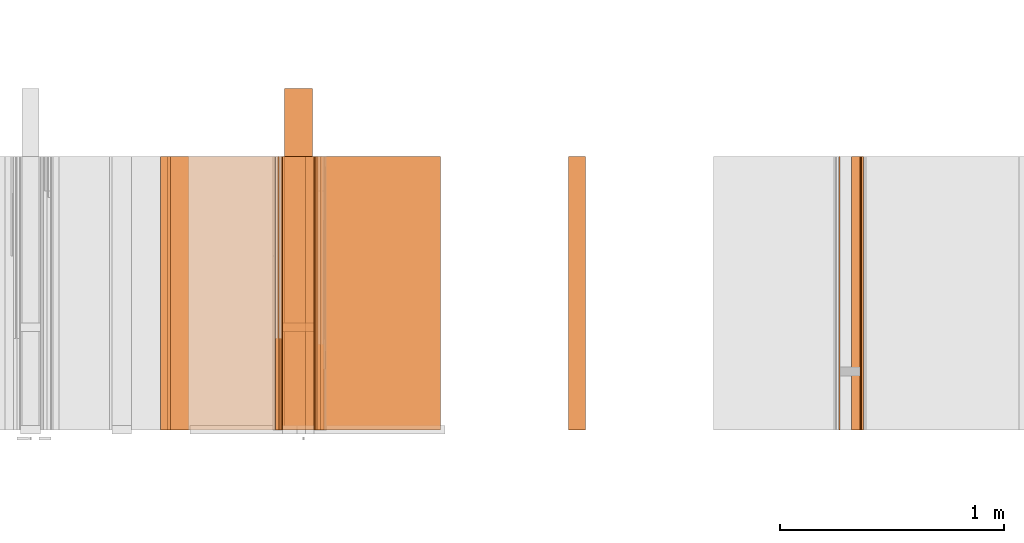
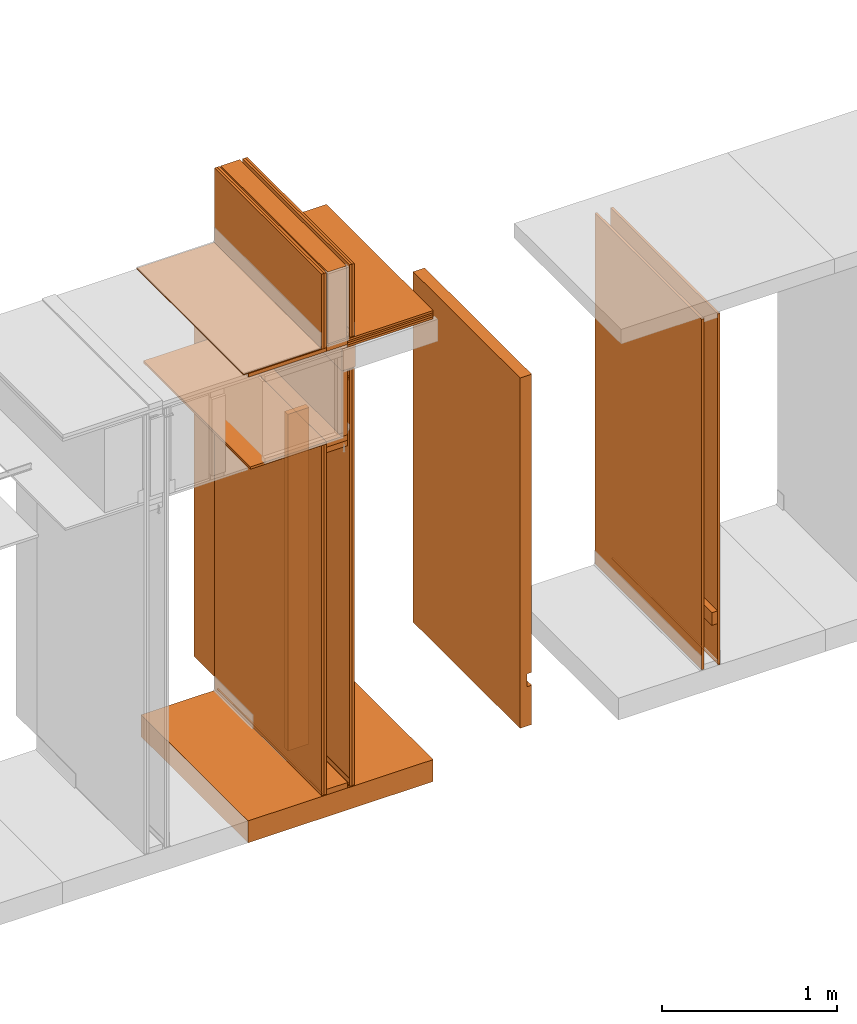
# One storey, part 36 of 64: 34 proxies.
"""IFC4 building model written with IfcOpenShell, lengths in feet."""

from ifc_helpers import new_model, entity, si_unit, converted_unit, frame, origin_with_axes, origin_2d_with_axis, place, context, subcontext, project, spatial, polyline, outline, extrude, material, element, save


model = new_model("IFC4")

# Units and contexts
model_context_1 = context("Model", 3, precision=1e-05, world=origin_with_axes())
plan_context = context("Plan", 2, precision=1e-05, world=origin_2d_with_axis())
model_context_2 = context("Model", 3, precision=1e-05, world=origin_with_axes())
context_of_model_1 = context(None, 3, precision=1e-05, world=origin_with_axes())
context_of_model_2 = context(None, 3, precision=1e-05, world=origin_with_axes())
body_context = subcontext(model_context_2, "Body", "Model", "MODEL_VIEW")
ifc_project = project(units=[converted_unit("PLANEANGLEUNIT", "degree", entity("IfcReal", 0.0174532925199433), si_unit("PLANEANGLEUNIT", "RADIAN"), dimensions=[0, 0, 0, 0, 0, 0, 0]), converted_unit("AREAUNIT", "square foot", entity("IfcReal", 0.09290304), si_unit("AREAUNIT", "SQUARE_METRE"), dimensions=[2, 0, 0, 0, 0, 0, 0]), converted_unit("LENGTHUNIT", "foot", entity("IfcReal", 0.3048), si_unit("LENGTHUNIT", "METRE"), dimensions=[1, 0, 0, 0, 0, 0, 0]), converted_unit("VOLUMEUNIT", "cubic foot", entity("IfcReal", 0.0283168467116885), si_unit("VOLUMEUNIT", "CUBIC_METRE"), dimensions=[3, 0, 0, 0, 0, 0, 0])], contexts=[model_context_1, plan_context, context_of_model_1, context_of_model_2])

# Site, building, storey
site_placement = place(None, origin_with_axes())
site = spatial("IfcSite", under=ifc_project, at=site_placement)
building_placement = place(site_placement, origin_with_axes())
building = spatial("IfcBuilding", under=site, at=building_placement, Name="Building")
storey_placement = place(building_placement, origin_with_axes())
storey = spatial("IfcBuildingStorey", under=building, at=storey_placement, Name="Storey")

# Proxies
ifc_material_1 = material(Category="sand")
proxy_1_placement = place(storey_placement, frame((1395.3228447381, 5.99999987860051, 0.0208333330815585), z_axis=(1.62920684942944e-07, -0.999999999999987, -1.23001694617954e-14), x_axis=(7.54979012640431e-08, 0.0, 0.999999999999997)))
element("IfcBuildingElementProxy", 1, at=proxy_1_placement, inside=storey, material=ifc_material_1, Name="Generic Models 138:Generic Models 1", PredefinedType="COMPLEX", context=body_context, shape_type="SweptSolid", body=[
    extrude(outline(polyline([(-0.0260419699942737, -4.00000004943587), (0.0260413650012626, -4.00000004943587), (0.0260419699942737, 4.00000004943587), (-0.0260413650012626, 4.00000004943587), (-0.0260419699942737, -4.00000004943587)])), frame((4.00000004943587, -0.0260413650012626, -3.91106639637913e-07), z_axis=(-1.16558848618949e-14, 0.0, -1.0), x_axis=(0.0, 1.0, 0.0)), (0.0, -1.16558848618949e-14, -1.0), 4.00000000752362),
])
proxy_2_placement = place(storey_placement, frame((1385.23442225819, 5.99999987860051, 8.01041683187009), z_axis=(4.37113882867379e-08, -0.999999999999999, -8.51092183247426e-15), x_axis=(1.94707183709394e-07, 0.0, 0.999999999999981)))
element("IfcBuildingElementProxy", 2, at=proxy_2_placement, inside=storey, Name="Generic Models 488:Generic Models 1", PredefinedType="COMPLEX", context=body_context, shape_type="SweptSolid", body=[
    extrude(outline(polyline([(-0.0260416674977682, -0.820312541457299), (0.0260416674977682, -0.820312541457299), (0.0260416644422479, 0.820312541457299), (-0.0260416674977682, 0.820312541457299), (-0.0260416674977682, -0.820312541457299)])), frame((0.0260418263848216, -0.820312541457299, -4.8889545663521e-07), z_axis=(0.0, 1.19209275339927e-07, -1.0), x_axis=(1.0, 1.94707169498542e-07, 0.0)), (-2.08445108396127e-10, 4.27917523637689e-09, -1.0), 4.00000000752362),
])
proxy_3_placement = place(storey_placement, frame((1387.2083528774, 5.99999987860051, 9.55989589215577), z_axis=(1.62920684942944e-07, -0.999999999999987, -1.23001694617954e-14), x_axis=(7.54979012640431e-08, 0.0, 0.999999999999997)))
element("IfcBuildingElementProxy", 3, at=proxy_3_placement, inside=storey, Name="Generic Models 490:Generic Models 1", PredefinedType="COMPLEX", context=body_context, shape_type="SweptSolid", body=[
    extrude(outline(polyline([(-0.250000003089742, -0.145833333098669), (0.24999997864558, -0.145833333098669), (0.24999997864558, 0.145833333098669), (-0.250000027533904, 0.145833320876588), (-0.250000003089742, -0.145833333098669)])), frame((0.250000003089742, -0.145833308654507, -3.91106593014374e-07), z_axis=(0.0, 0.0, -1.0), x_axis=(-1.0, -9.77766489995702e-08, 0.0)), (-2.54626741913455e-09, 0.0, -1.0), 4.00000000752362),
])
proxy_4_placement = place(storey_placement, frame((1387.33330674059, 5.99999987860051, 10.1588545196013), z_axis=(4.37113882867379e-08, -0.999999999999999, -8.51092183247426e-15), x_axis=(1.94707183709394e-07, 0.0, 0.999999999999981)))
element("IfcBuildingElementProxy", 4, at=proxy_4_placement, inside=storey, Name="Generic Models 491:Generic Models 1", PredefinedType="COMPLEX", context=body_context, shape_type="SweptSolid", body=[
    extrude(outline(polyline([(-0.0208335148850138, -0.92447918700421), (0.0208331543336234, -0.92447918700421), (0.0208335148850138, 0.92447918700421), (-0.0208331543336234, 0.92447918700421), (-0.0208335148850138, -0.92447918700421)])), frame((0.0208335148850138, -0.92447918700421, -5.0131307678986e-07), z_axis=(0.0, 1.19209289550781e-07, -1.0), x_axis=(-1.0, 0.0, 0.0)), (0.0, -3.01153102455487e-09, -1.0), 4.00000000752362),
])
proxy_5_placement = place(storey_placement, frame((1387.33330674059, 5.99999987860051, 10.1093748423058), z_axis=(4.37113882867379e-08, -0.999999999999999, -8.51092183247426e-15), x_axis=(1.94707183709394e-07, 0.0, 0.999999999999981)))
element("IfcBuildingElementProxy", 5, at=proxy_5_placement, inside=storey, Name="Generic Models 492:Generic Models 1", PredefinedType="COMPLEX", context=body_context, shape_type="SweptSolid", body=[
    extrude(outline(polyline([(-0.0247397637874709, -0.92447918700421), (0.0247394032360805, -0.92447918700421), (0.0247397637874709, 0.92447918700421), (-0.0247394032360805, 0.92447918700421), (-0.0247397637874709, -0.92447918700421)])), frame((0.0247397637874709, -0.92447918700421, -5.0131307678986e-07), z_axis=(0.0, 1.19209289550781e-07, -1.0), x_axis=(-1.0, 0.0, 0.0)), (0.0, -3.01153102455487e-09, -1.0), 4.00000000752362),
])
proxy_6_placement = place(storey_placement, frame((1387.2083528774, 5.99999987860051, 8.06249971464863), z_axis=(4.37113882867379e-08, -0.999999999999999, -8.51092183247426e-15), x_axis=(1.94707183709394e-07, 0.0, 0.999999999999981)))
element("IfcBuildingElementProxy", 6, at=proxy_6_placement, inside=storey, Name="Generic Models 493:Generic Models 1", PredefinedType="COMPLEX", context=body_context, shape_type="SweptSolid", body=[
    extrude(outline(polyline([(-0.748697844311947, -0.0625000007724355), (0.748697893200271, -0.0625000007724355), (0.748697893200271, 0.0625000007724355), (-0.748697893200271, 0.0625000007724355), (-0.748697844311947, -0.0625000007724355)])), frame((0.748697893200271, -0.0624998541074631, -3.98557174431872e-07), z_axis=(-2.35432113122316e-14, 1.19209303761636e-07, -1.0), x_axis=(-1.0, -1.95893392174185e-07, 0.0)), (3.06085023993319e-09, 4.40009660651608e-11, -1.0), 4.00000000752362),
])
ifc_material_2 = material(Category="InsulationBatt")
proxy_7_placement = place(storey_placement, frame((1386.90327721944, 5.99999987860051, 10.2830629336239), z_axis=(4.37113882867379e-08, -0.999999999999999, -8.51092183247426e-15), x_axis=(1.94707183709394e-07, 0.0, 0.999999999999981)))
element("IfcBuildingElementProxy", 7, at=proxy_7_placement, inside=storey, material=ifc_material_2, Name="Generic Models 496:Generic Models 1", PredefinedType="COMPLEX", context=body_context, shape_type="SweptSolid", body=[
    extrude(outline(polyline([(-0.820806020201035, -0.20460231752768), (0.820806020201035, -0.20460231752768), (0.820805922424386, 0.20460231752768), (-0.820806020201035, 0.20460231752768), (-0.820806020201035, -0.20460231752768)])), frame((0.820806020201035, -0.204602158640626, -4.15497091384278e-07), z_axis=(-2.31266422028378e-14, 1.19209289550781e-07, -1.0), x_axis=(1.0, 1.94707183709397e-07, 0.0)), (-9.9594013036608e-09, 3.24397553264077e-09, -1.0), 4.00000000752362),
])
proxy_8_placement = place(storey_placement, frame((1391.05729230746, 5.99999909638733, 0.0546877993529863), z_axis=(1.62920684942944e-07, -0.999999999999987, -1.23001694617954e-14), x_axis=(7.54979012640431e-08, 0.0, 0.999999999999997)))
element("IfcBuildingElementProxy", 8, at=proxy_8_placement, inside=storey, material=ifc_material_2, Name="Generic Models 157:Generic Models 1", PredefinedType="COMPLEX", context=body_context, shape_type="SweptSolid", body=[
    extrude(outline(polyline([(1.62270213440647, -0.0872395766454106), (2.52313129701639, -0.0872395766454106), (2.52313129701639, 0.162760426444331), (-5.47686899740865, 0.162760365333926), (-5.47686860630206, -0.0872396194226942), (1.33103546820913, -0.0872395766454106), (1.33103546820913, 0.0117187520545318), (1.62270213440647, 0.0117187635127328), (1.62270213440647, -0.0872395766454106)])), frame((2.52313129701639, -0.162760218668954, -3.91106593014374e-07), z_axis=(-6.06266415447755e-15, -2.11475937672914e-14, -1.0), x_axis=(-1.0, -8.14417049355143e-08, 0.0)), (3.31386740271e-09, 5.71793279391386e-10, -1.0), 4.00000000752362),
])
proxy_9_placement = place(storey_placement, frame((1394.97912149104, 5.99999987860051, 0.0208333330815585), z_axis=(1.62920684942944e-07, -0.999999999999987, -1.23001694617954e-14), x_axis=(7.54979012640431e-08, 0.0, 0.999999999999997)))
element("IfcBuildingElementProxy", 9, at=proxy_9_placement, inside=storey, material=ifc_material_1, Name="Generic Models 16:Generic Models 1", PredefinedType="COMPLEX", context=body_context, shape_type="SweptSolid", body=[
    extrude(outline(polyline([(-0.0260419699942737, -4.00000004943587), (0.0260413650012626, -4.00000004943587), (0.0260419699942737, 4.00000004943587), (-0.0260413650012626, 4.00000004943587), (-0.0260419699942737, -4.00000004943587)])), frame((4.00000004943587, -0.0260413650012626, -3.91106639637913e-07), z_axis=(-1.16558848618949e-14, 0.0, -1.0), x_axis=(0.0, 1.0, 0.0)), (0.0, -1.16558848618949e-14, -1.0), 4.00000000752362),
])
ifc_material_3 = material(Name="ACOUSTICAL SEALANT OR FIRE SEALANT, IF RATED WALL", Category="sealant")
proxy_10_placement = place(storey_placement, frame((1395.33916483401, 5.99999987860051, 0.0), z_axis=(1.62920684942944e-07, -0.999999999999987, -1.23001694617954e-14), x_axis=(7.54979012640431e-08, 0.0, 0.999999999999997)))
element("IfcBuildingElementProxy", 10, at=proxy_10_placement, inside=storey, material=ifc_material_3, Name="Generic Models 17:Generic Models 1", PredefinedType="COMPLEX", context=body_context, shape_type="SweptSolid", body=[
    extrude(outline(polyline([(0.0200664020800997, 8.59128858751497e-10), (-0.0066432067293312, 0.0162221848221589), (-0.0159632080916579, 0.00969531855440828), (-0.0174579961015171, -0.00158422060519838), (0.00925161041627367, -0.0178064048544472), (0.0107464022455331, -0.00652686626775058), (0.0200664020800997, 8.59128858751497e-10)])), frame((0.0104166680685394, -0.0185779756634176, -1.2812678144933e-16), z_axis=(-1.23001677677296e-14, 6.41066287393143e-22, -1.0), x_axis=(-0.519109845161438, -0.854707539081573, 6.38513764431026e-15)), (1.60595958753618e-09, 3.2119169546263e-09, -1.0), 4.0),
])
ifc_material_4 = material(Name="2X BLOCKING - GRAB BARS, WALL HUNG CABINETS, ETC", Category="wood1")
proxy_11_placement = place(storey_placement, frame((1395.19789087491, 5.99999987860051, 0.955116717521287), z_axis=(1.62920684942944e-07, -0.999999999999987, -1.23001694617954e-14), x_axis=(7.54979012640431e-08, 0.0, 0.999999999999997)))
element("IfcBuildingElementProxy", 11, at=proxy_11_placement, inside=storey, material=ifc_material_4, Name="Generic Models 197:Generic Models 1", PredefinedType="COMPLEX", context=body_context, shape_type="SweptSolid", body=[
    extrude(outline(polyline([(-0.062500006883476, -0.145833333098669), (0.0624999885503545, -0.145833333098669), (0.0625000129945165, 0.145833320876588), (-0.0624999885503545, 0.145833333098669), (-0.062500006883476, -0.145833333098669)])), frame((0.145833333098669, -0.0624999885503545, -3.91106593014374e-07), z_axis=(0.0, 0.0, -1.0), x_axis=(0.0, -1.0, 0.0)), (0.0, 0.0, -1.0), 4.00000000752362),
])
ifc_material_5 = material(Name="STRUCTURAL FLOOR", Category="concrete")
proxy_12_placement = place(storey_placement, frame((1385.18225802524, 5.99999987860051, -0.500000006179484), z_axis=(4.37113882867379e-08, -0.999999999999999, -8.51092183247426e-15), x_axis=(1.94707183709394e-07, 0.0, 0.999999999999981)))
element("IfcBuildingElementProxy", 12, at=proxy_12_placement, inside=storey, material=ifc_material_5, Name="Generic Models 238:Generic Models 1", PredefinedType="COMPLEX", context=body_context, shape_type="SweptSolid", body=[
    extrude(outline(polyline([(-0.250000003089742, -2.00000002471794), (0.250000003089742, -2.00000002471794), (0.250000003089742, 2.00000002471794), (-0.250000003089742, 2.00000002471794), (-0.250000003089742, -2.00000002471794)])), frame((0.250000394196335, -2.00000002471794, -6.29525198374314e-07), z_axis=(0.0, 1.19209289550781e-07, -1.0), x_axis=(1.0, 1.94707183709397e-07, 0.0)), (4.23038687413779e-10, -9.26340160134487e-09, -1.0), 4.00000000752362),
])
proxy_13_placement = place(storey_placement, frame((1386.87504245227, 5.99999987860051, 0.0), z_axis=(4.37113882867379e-08, -0.999999999999999, -8.51092183247426e-15), x_axis=(1.94707183709394e-07, 0.0, 0.999999999999981)))
element("IfcBuildingElementProxy", 13, at=proxy_13_placement, inside=storey, Name="Generic Models 435:Generic Models 1", PredefinedType="COMPLEX", context=body_context, shape_type="SweptSolid", body=[
    extrude(outline(polyline([(-0.229166659313863, -0.0625000007724355), (0.229166659313863, -0.0625000007724355), (0.229166659313863, 0.0625000007724355), (-0.229166683758025, 0.062499994661395), (-0.229166659313863, -0.0625000007724355)])), frame((0.0625000435497191, -0.229166659313863, -4.18425376004021e-07), z_axis=(0.0, 1.1920923981279e-07, -1.0), x_axis=(-1.94707183709397e-07, 1.0, 1.1920923981279e-07)), (-6.05387917573807e-09, -4.60778332156409e-10, -1.0), 4.00000000752362),
])
proxy_14_placement = place(storey_placement, frame((1387.37495802832, 5.99999987860051, 0.0208333330815585), z_axis=(4.37113882867379e-08, -0.999999999999999, -8.51092183247426e-15), x_axis=(1.94707183709394e-07, 0.0, 0.999999999999981)))
element("IfcBuildingElementProxy", 14, at=proxy_14_placement, inside=storey, Name="Generic Models 444:Generic Models 1", PredefinedType="COMPLEX", context=body_context, shape_type="SweptSolid", body=[
    extrude(outline(polyline([(-4.75911487118779, -0.0260416674977682), (4.75911487118779, -0.0260416674977682), (4.75911487118779, 0.0260416705532884), (-4.75911487118779, 0.0260416674977682), (-4.75911487118779, -0.0260416674977682)])), frame((4.75911487118779, -0.02604074167513, -3.94211021364806e-07), z_axis=(-3.29951011987777e-14, 1.19209154547661e-07, -1.0), x_axis=(1.0, 1.94707197920252e-07, -9.79668311805546e-15)), (-1.26761301455502e-09, 1.58962953911157e-10, -1.0), 4.00000000752362),
])
ifc_material_6 = material(Name="ACOUSTICAL SEALANT", Category="sealant")
proxy_15_placement = place(storey_placement, frame((1386.82287821932, 5.99999987860051, 0.0), z_axis=(4.37113882867379e-08, -0.999999999999999, -8.51092183247426e-15), x_axis=(1.94707183709394e-07, 0.0, 0.999999999999981)))
element("IfcBuildingElementProxy", 15, at=proxy_15_placement, inside=storey, material=ifc_material_6, Name="Generic Models 450:Generic Models 1", PredefinedType="COMPLEX", context=body_context, shape_type="SweptSolid", body=[
    extrude(outline(polyline([(0.0175297320783725, 1.21719171997307e-09), (-0.00760452534631872, 0.0185696447874344), (-0.0101125697065096, 0.00747135049587707), (-0.0199842895564484, 0.00181347361657025), (0.0051499686321229, -0.0167561721257142), (0.0150216861904215, -0.0110982927637972), (0.0175297320783725, 1.21719171997307e-09)])), frame((0.0104166711240596, -0.0171509025657545, -3.9315117507417e-07), z_axis=(1.14723269946382e-12, 1.19208550586336e-07, -1.0), x_axis=(-0.594228446483612, -0.804296314716339, -9.58762740310704e-08)), (-1.04803887790439e-10, 1.77274347978873e-10, -1.0), 4.00000000752362),
])
proxy_16_placement = place(storey_placement, frame((1386.77081410966, 5.99999987860051, 10.2083334146835), z_axis=(4.37113882867379e-08, -0.999999999999999, -8.51092183247426e-15), x_axis=(1.94707183709394e-07, 0.0, 0.999999999999981)))
element("IfcBuildingElementProxy", 16, at=proxy_16_placement, inside=storey, material=ifc_material_1, Name="Generic Models 452:Generic Models 1", PredefinedType="COMPLEX", context=body_context, shape_type="SweptSolid", body=[
    extrude(outline(polyline([(-0.0260416674977682, -0.858170779671256), (0.0260416674977682, -0.858170779671256), (0.0260416674977682, 0.858170779671256), (-0.0260416644422479, 0.858170779671256), (-0.0260416674977682, -0.858170779671256)])), frame((0.858170779671256, -0.026041499444154, -3.94210974741267e-07), z_axis=(-2.33946146282289e-14, 1.19209154547661e-07, -1.0), x_axis=(-1.94707169498542e-07, 1.0, 1.19209147442234e-07)), (2.84252066329316e-10, -1.26763999297452e-09, -1.0), 4.00000000752362),
])
proxy_17_placement = place(storey_placement, frame((1386.87504245227, 5.99999987860051, 7.81249968711472), z_axis=(4.37113882867379e-08, -0.999999999999999, -8.51092183247426e-15), x_axis=(1.94707183709394e-07, 0.0, 0.999999999999981)))
element("IfcBuildingElementProxy", 17, at=proxy_17_placement, inside=storey, Name="Generic Models 455:Generic Models 1", PredefinedType="COMPLEX", context=body_context, shape_type="SweptSolid", body=[
    extrude(outline(polyline([(-0.229166659313863, -0.0625000007724355), (0.229166659313863, -0.0625000007724355), (0.229166659313863, 0.0625000007724355), (-0.229166683758025, 0.062499994661395), (-0.229166659313863, -0.0625000007724355)])), frame((0.0625000435497191, -0.229166659313863, -4.18425376004021e-07), z_axis=(0.0, 1.1920923981279e-07, -1.0), x_axis=(-1.94707183709397e-07, 1.0, 1.1920923981279e-07)), (-6.05387917573807e-09, -4.60778332156409e-10, -1.0), 4.00000000752362),
])
proxy_18_placement = place(storey_placement, frame((1386.90327721944, 6.99999998873613, 0.125000001544871), z_axis=(4.37113882867379e-08, -0.999999999999999, -8.51092183247426e-15), x_axis=(1.94707183709394e-07, 0.0, 0.999999999999981)))
element("IfcBuildingElementProxy", 18, at=proxy_18_placement, inside=storey, Name="Generic Models 456:Generic Models 1", PredefinedType="COMPLEX", context=body_context, shape_type="SweptSolid", body=[
    extrude(outline(polyline([(-0.20460231752768, -3.83239327453253), (0.20460231752768, -3.83239327453253), (0.20460231752768, 3.83239327453253), (-0.20460231752768, 3.83239327453253), (-0.20460231752768, -3.83239327453253)])), frame((3.83239327453253, -0.204601571980737, -4.15497138007817e-07), z_axis=(-2.9337992403294e-14, 1.19209289550781e-07, -1.0), x_axis=(-1.94707183709397e-07, 1.0, 1.19209289550781e-07)), (-1.17899273677224e-10, -9.95937821102189e-09, -1.0), 4.00000000752362),
])
proxy_19_placement = place(storey_placement, frame((1386.87504245227, 5.99999987860051, 7.93749970088168), z_axis=(4.37113882867379e-08, -0.999999999999999, -8.51092183247426e-15), x_axis=(1.94707183709394e-07, 0.0, 0.999999999999981)))
element("IfcBuildingElementProxy", 19, at=proxy_19_placement, inside=storey, Name="Generic Models 457:Generic Models 1", PredefinedType="COMPLEX", context=body_context, shape_type="SweptSolid", body=[
    extrude(outline(polyline([(-0.229166659313863, -0.0625000007724355), (0.229166659313863, -0.0625000007724355), (0.229166659313863, 0.0625000007724355), (-0.229166683758025, 0.062499994661395), (-0.229166659313863, -0.0625000007724355)])), frame((0.0625000435497191, -0.229166659313863, -4.18425376004021e-07), z_axis=(0.0, 1.1920923981279e-07, -1.0), x_axis=(-1.94707183709397e-07, 1.0, 1.1920923981279e-07)), (-6.05387917573807e-09, -4.60778332156409e-10, -1.0), 4.00000000752362),
])
proxy_20_placement = place(storey_placement, frame((1386.82287821932, 5.99999987860051, 10.2083334146835), z_axis=(4.37113882867379e-08, -0.999999999999999, -8.51092183247426e-15), x_axis=(1.94707183709394e-07, 0.0, 0.999999999999981)))
element("IfcBuildingElementProxy", 20, at=proxy_20_placement, inside=storey, Name="Generic Models 458:Generic Models 1", PredefinedType="COMPLEX", context=body_context, shape_type="SweptSolid", body=[
    extrude(outline(polyline([(-0.858170779671256, -0.0260416674977682), (0.858170779671256, -0.0260416674977682), (0.858170779671256, 0.0260416644422479), (-0.858170779671256, 0.0260416674977682), (-0.858170779671256, -0.0260416674977682)])), frame((0.858170779671256, -0.026041499444154, -3.94210974741267e-07), z_axis=(-2.33946146282289e-14, 1.19209154547661e-07, -1.0), x_axis=(1.0, 1.94707183709397e-07, 0.0)), (-1.26763999297452e-09, -2.84249151993876e-10, -1.0), 4.00000000752362),
])
proxy_21_placement = place(storey_placement, frame((1386.82287821932, 5.99999987860051, 0.0208333330815585), z_axis=(4.37113882867379e-08, -0.999999999999999, -8.51092183247426e-15), x_axis=(1.94707183709394e-07, 0.0, 0.999999999999981)))
element("IfcBuildingElementProxy", 21, at=proxy_21_placement, inside=storey, Name="Generic Models 459:Generic Models 1", PredefinedType="COMPLEX", context=body_context, shape_type="SweptSolid", body=[
    extrude(outline(polyline([(-3.9947916829367, -0.0260416674977682), (3.9947916829367, -0.0260416674977682), (3.9947916829367, 0.0260416674977682), (-3.9947916829367, 0.0260416644422479), (-3.9947916829367, -0.0260416674977682)])), frame((3.9947916829367, -0.0260408883401024, -3.94211021364806e-07), z_axis=(-2.90771875707026e-14, 1.19209140336807e-07, -1.0), x_axis=(-1.0, -1.95043384110249e-07, 5.83554074000078e-15)), (1.26980481685024e-09, 4.38377840972226e-11, -1.0), 4.00000000752362),
])
proxy_22_placement = place(storey_placement, frame((1386.77081410966, 5.99999987860051, 0.0208333330815585), z_axis=(4.37113882867379e-08, -0.999999999999999, -8.51092183247426e-15), x_axis=(1.94707183709394e-07, 0.0, 0.999999999999981)))
element("IfcBuildingElementProxy", 22, at=proxy_22_placement, inside=storey, material=ifc_material_1, Name="Generic Models 460:Generic Models 1", PredefinedType="COMPLEX", context=body_context, shape_type="SweptSolid", body=[
    extrude(outline(polyline([(-3.9947916829367, -0.0260416674977682), (3.9947916829367, -0.0260416674977682), (3.9947916829367, 0.0260416644422479), (-3.9947916829367, 0.0260416674977682), (-3.9947916829367, -0.0260416674977682)])), frame((3.9947916829367, -0.0260408883401024, -3.94211021364806e-07), z_axis=(-2.90771875707026e-14, 1.19209140336807e-07, -1.0), x_axis=(1.0, 1.94707183709397e-07, -5.83554074000078e-15)), (-1.26761612317949e-09, -3.79597214772431e-10, -1.0), 4.00000000752362),
])
proxy_23_placement = place(storey_placement, frame((1387.42712226127, 5.99999987860051, 0.0208333330815585), z_axis=(4.37113882867379e-08, -0.999999999999999, -8.51092183247426e-15), x_axis=(1.94707183709394e-07, 0.0, 0.999999999999981)))
element("IfcBuildingElementProxy", 23, at=proxy_23_placement, inside=storey, Name="Generic Models 461:Generic Models 1", PredefinedType="COMPLEX", context=body_context, shape_type="SweptSolid", body=[
    extrude(outline(polyline([(-4.75911487118779, -0.0260416705532884), (4.75911487118779, -0.0260416705532884), (4.75911487118779, 0.0260416644422479), (-4.75911487118779, 0.0260416674977682), (-4.75911487118779, -0.0260416705532884)])), frame((4.75911487118779, -0.0260407386196098, -3.94211067988345e-07), z_axis=(-3.29951011987777e-14, 1.19209154547661e-07, -1.0), x_axis=(-1.0, -1.94536738717943e-07, 9.79668311805546e-15)), (1.26650312459731e-09, 4.3826126755464e-11, -1.0), 4.00000000752362),
])
proxy_24_placement = place(storey_placement, frame((1387.37495802832, 5.99999987860051, 10.2708330304604), z_axis=(4.37113882867379e-08, -0.999999999999999, -8.51092183247426e-15), x_axis=(1.94707183709394e-07, 0.0, 0.999999999999981)))
element("IfcBuildingElementProxy", 24, at=proxy_24_placement, inside=storey, Name="Generic Models 462:Generic Models 1", PredefinedType="COMPLEX", context=body_context, shape_type="SweptSolid", body=[
    extrude(outline(polyline([(-0.0260416674977682, -0.826920776229518), (0.0260416674977682, -0.826920776229518), (0.0260416674977682, 0.826920776229518), (-0.0260416644422479, 0.826920776229518), (-0.0260416674977682, -0.826920776229518)])), frame((0.826920776229518, -0.0260415055551945, -3.94210974741267e-07), z_axis=(-2.34116179676121e-14, 1.19209154547661e-07, -1.0), x_axis=(-1.94707169498542e-07, 1.0, 1.19209147442234e-07)), (2.77643186219478e-10, -1.26764032604143e-09, -1.0), 4.00000000752362),
])
proxy_25_placement = place(storey_placement, frame((1387.42712226127, 5.99999987860051, 10.2708330304604), z_axis=(4.37113882867379e-08, -0.999999999999999, -8.51092183247426e-15), x_axis=(1.94707183709394e-07, 0.0, 0.999999999999981)))
element("IfcBuildingElementProxy", 25, at=proxy_25_placement, inside=storey, Name="Generic Models 463:Generic Models 1", PredefinedType="COMPLEX", context=body_context, shape_type="SweptSolid", body=[
    extrude(outline(polyline([(-0.0260416674977682, -0.825750194196626), (0.0260416674977682, -0.825750194196626), (0.0260416674977682, 0.825750194196626), (-0.0260416644422479, 0.825750194196626), (-0.0260416674977682, -0.825750194196626)])), frame((0.825750194196626, -0.0260415055551945, -3.94210974741267e-07), z_axis=(-2.34448064125514e-14, 1.19209161653089e-07, -1.0), x_axis=(-1.94707169498542e-07, 1.0, 1.19209147442234e-07)), (3.34622968223286e-10, -1.26764032604143e-09, -1.0), 4.00000000752362),
])
for number, where, z_axis, x_axis, name in (
    (26, (1387.33330674059, 5.99999987860051, 10.2719844482702), (4.37113882867379e-08, -0.999999999999999, -8.51092183247426e-15), (1.94707183709394e-07, 0.0, 0.999999999999981), "Generic Models 464:Generic Models 1"),
    (27, (1387.33330674059, 5.99999987860051, 0.0115680431010901), (4.37113882867379e-08, -0.999999999999999, -8.51092183247426e-15), (1.94707183709394e-07, 0.0, 0.999999999999981), "Generic Models 469:Generic Models 1"),
):
    element("IfcBuildingElementProxy", number, at=place(storey_placement, frame(where, z_axis=z_axis, x_axis=x_axis)), inside=storey, Name=name, PredefinedType="COMPLEX", context=body_context, shape_type="SweptSolid", body=[
        extrude(outline(polyline([(0.0909011349023327, -1.52771368754651e-09), (0.106510742912142, -0.0224037100793183), (0.110784095768228, -0.0194262812803854), (0.0939412186719145, 0.00474751612851078), (-0.0261054912049157, 0.0262034236847025), (-0.0684096397260043, -0.00327164942784885), (-0.107302623764267, 0.00367967978369181), (-0.1082189865117, -0.00144740758497962), (-0.0672022875623284, -0.00877830727280086), (-0.0248981451522803, 0.0206967635481103), (0.0909011349023327, -1.52771368754651e-09)])), frame((0.106276176732982, -0.0204650267807087, -3.93546216320895e-07), z_axis=(-2.86421862789876e-12, 1.19209985882662e-07, -1.0), x_axis=(0.984400570392609, -0.175941362977028, -2.09736619183332e-08)), (-1.20826360028303e-09, -9.42844552431765e-11, -1.0), 4.00000000752362),
    ])
proxy_26_placement = place(storey_placement, frame((1386.87504245227, 3.44270835398376, 0.125000001544871), z_axis=(0.0, 0.0, 1.0), x_axis=(1.0, 0.0, 0.0)))
element("IfcBuildingElementProxy", 28, at=proxy_26_placement, inside=storey, Name="Generic Models 471:Generic Models 1", PredefinedType="COMPLEX", context=body_context, shape_type="SweptSolid", body=[
    extrude(outline(polyline([(-0.229166659313863, -0.0625000007724355), (0.229166659313863, -0.0625000007724355), (0.229166659313863, 0.0625000007724355), (-0.229166659313863, 0.0625000007724355), (-0.229166659313863, -0.0625000007724355)])), frame((0.229166659313863, 0.0625000007724355, 0.0), z_axis=(0.0, 0.0, -1.0), x_axis=(-1.0, 0.0, 0.0)), (0.0, 0.0, -1.0), 7.6848958487616),
])
proxy_27_placement = place(storey_placement, frame((1387.33330674059, 5.99999987860051, 10.0598959472236), z_axis=(4.37113882867379e-08, -0.999999999999999, -8.51092183247426e-15), x_axis=(1.94707183709394e-07, 0.0, 0.999999999999981)))
element("IfcBuildingElementProxy", 29, at=proxy_27_placement, inside=storey, Name="Generic Models 474:Generic Models 1", PredefinedType="COMPLEX", context=body_context, shape_type="SweptSolid", body=[
    extrude(outline(polyline([(-0.0247397637874709, -0.92447918700421), (0.0247394032360805, -0.92447918700421), (0.0247397637874709, 0.92447918700421), (-0.0247394032360805, 0.92447918700421), (-0.0247397637874709, -0.92447918700421)])), frame((0.0247397637874709, -0.92447918700421, -5.0131307678986e-07), z_axis=(0.0, 1.19209289550781e-07, -1.0), x_axis=(-1.0, 0.0, 0.0)), (0.0, -3.01153102455487e-09, -1.0), 4.00000000752362),
])
proxy_28_placement = place(storey_placement, frame((1386.87504245227, 5.99999987860051, 10.1250003329099), z_axis=(4.37113882867379e-08, -0.999999999999999, -8.51092183247426e-15), x_axis=(1.94707183709394e-07, 0.0, 0.999999999999981)))
element("IfcBuildingElementProxy", 30, at=proxy_28_placement, inside=storey, Name="Generic Models 475:Generic Models 1", PredefinedType="COMPLEX", context=body_context, shape_type="SweptSolid", body=[
    extrude(outline(polyline([(-0.229166659313863, -0.0625000007724355), (0.229166659313863, -0.0625000007724355), (0.229166659313863, 0.0625000007724355), (-0.229166683758025, 0.062499994661395), (-0.229166659313863, -0.0625000007724355)])), frame((0.0625000435497191, -0.229166659313863, -4.18425376004021e-07), z_axis=(0.0, 1.1920923981279e-07, -1.0), x_axis=(-1.94707183709397e-07, 1.0, 1.1920923981279e-07)), (-6.05387917573807e-09, -4.60778332156409e-10, -1.0), 4.00000000752362),
])
proxy_29_placement = place(storey_placement, frame((1387.33330674059, 5.99999987860051, 10.2005206693814), z_axis=(4.37113882867379e-08, -0.999999999999999, -8.51092183247426e-15), x_axis=(1.94707183709394e-07, 0.0, 0.999999999999981)))
element("IfcBuildingElementProxy", 31, at=proxy_29_placement, inside=storey, Name="Generic Models 476:Generic Models 1", PredefinedType="COMPLEX", context=body_context, shape_type="SweptSolid", body=[
    extrude(outline(polyline([(-0.0247397637874709, -0.92447918700421), (0.0247394032360805, -0.92447918700421), (0.0247397637874709, 0.92447918700421), (-0.0247394032360805, 0.92447918700421), (-0.0247397637874709, -0.92447918700421)])), frame((0.0247397637874709, -0.92447918700421, -5.0131307678986e-07), z_axis=(0.0, 1.19209289550781e-07, -1.0), x_axis=(-1.0, 0.0, 0.0)), (0.0, -3.01153102455487e-09, -1.0), 4.00000000752362),
])
proxy_30_placement = place(storey_placement, frame((1385.19267084717, 5.99999987860051, 10.1250003329099), z_axis=(4.37113882867379e-08, -0.999999999999999, -8.51092183247426e-15), x_axis=(1.94707183709394e-07, 0.0, 0.999999999999981)))
element("IfcBuildingElementProxy", 32, at=proxy_30_placement, inside=storey, Name="Generic Models 477:Generic Models 1", PredefinedType="COMPLEX", context=body_context, shape_type="SweptSolid", body=[
    extrude(outline(polyline([(-0.841145811900692, -0.0416666692186372), (0.841145811900692, -0.0416666692186372), (0.841145811900692, 0.0416666692186372), (-0.841145811900692, 0.0416666722741574), (-0.841145811900692, -0.0416666692186372)])), frame((0.0416668342167311, -0.841145811900692, -4.91378999315555e-07), z_axis=(0.0, 1.19209303761636e-07, -1.0), x_axis=(-1.94707183709397e-07, 1.0, 1.19209303761636e-07)), (-5.0397268580582e-09, 3.0524130445464e-10, -1.0), 4.00000000752362),
])
proxy_31_placement = place(storey_placement, frame((1387.33330674059, 5.99999987860051, 9.30323453712964), z_axis=(4.37113882867379e-08, -0.999999999999999, -8.51092183247426e-15), x_axis=(1.94707183709394e-07, 0.0, 0.999999999999981)))
element("IfcBuildingElementProxy", 33, at=proxy_31_placement, inside=storey, Name="Generic Models 479:Generic Models 1", PredefinedType="COMPLEX", context=body_context, shape_type="SweptSolid", body=[
    extrude(outline(polyline([(0.0909011349023327, -1.52771368754651e-09), (0.106510742912142, -0.0224037100793183), (0.110784095768228, -0.0194262812803854), (0.0939412186719145, 0.00474751612851078), (-0.0261054912049157, 0.0262034236847025), (-0.0684096397260043, -0.00327164942784885), (-0.107302623764267, 0.00367967978369181), (-0.1082189865117, -0.00144740758497962), (-0.0672022875623284, -0.00877830727280086), (-0.0248981451522803, 0.0206967635481103), (0.0909011349023327, -1.52771368754651e-09)])), frame((0.106276176732982, -0.0204650267807087, -3.93546216320895e-07), z_axis=(-2.86421862789876e-12, 1.19209985882662e-07, -1.0), x_axis=(0.984400570392609, -0.175941362977028, -2.09736619183332e-08)), (-1.20826360028303e-09, -9.42844552431765e-11, -1.0), 4.00000000752362),
])
proxy_32_placement = place(storey_placement, frame((1385.08854262785, 5.99999987860051, 10.2083334146835), z_axis=(4.37113882867379e-08, -0.999999999999999, -8.51092183247426e-15), x_axis=(1.94707183709394e-07, 0.0, 0.999999999999981)))
element("IfcBuildingElementProxy", 34, at=proxy_32_placement, inside=storey, Name="Generic Models 480:Generic Models 1", PredefinedType="COMPLEX", context=body_context, shape_type="SweptSolid", body=[
    extrude(outline(polyline([(0.841210344488539, 1.52776231444079e-09), (0.840952409690446, 0.0208317411555041), (-0.841210442265188, -1.5277603110856e-09), (-0.840952409690446, -0.0208317411555041), (0.841210344488539, 1.52776231444079e-09)])), frame((0.0104168307749931, -0.841145811900692, -4.91378999315555e-07), z_axis=(0.0, 1.19209303761636e-07, -1.0), x_axis=(-0.0123831462115049, 0.999923288822174, 1.19200159076627e-07)), (-9.4569436726033e-09, -5.15735579242893e-11, -1.0), 4.00000000752362),
])

save(model, "model.ifc")
